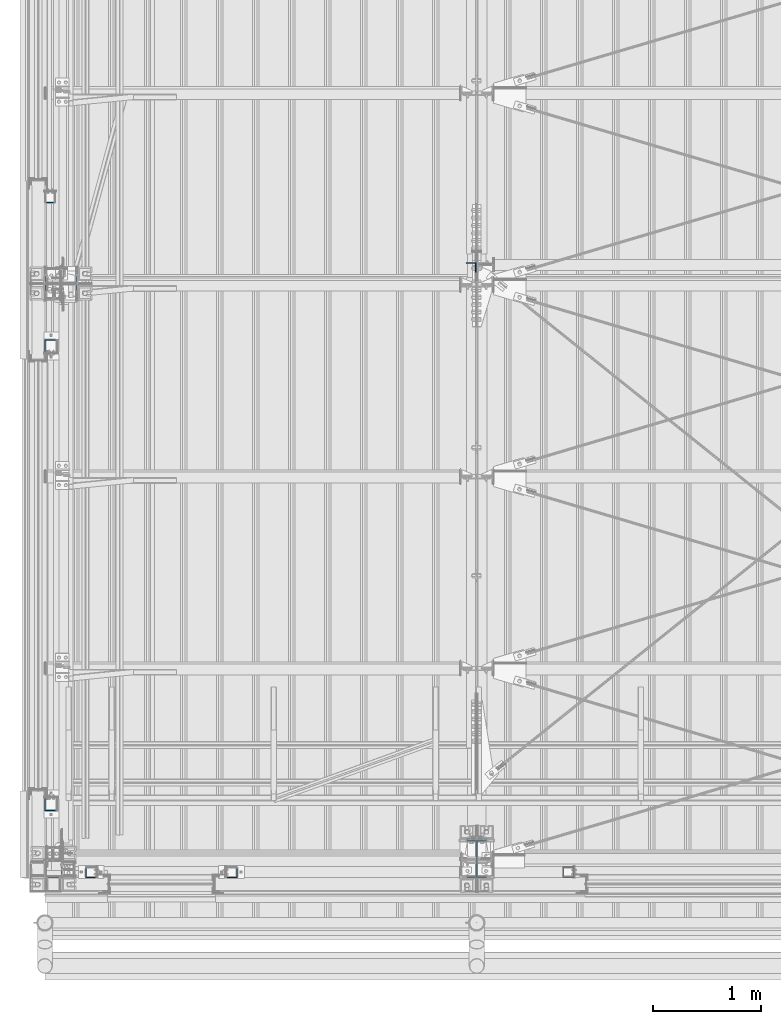
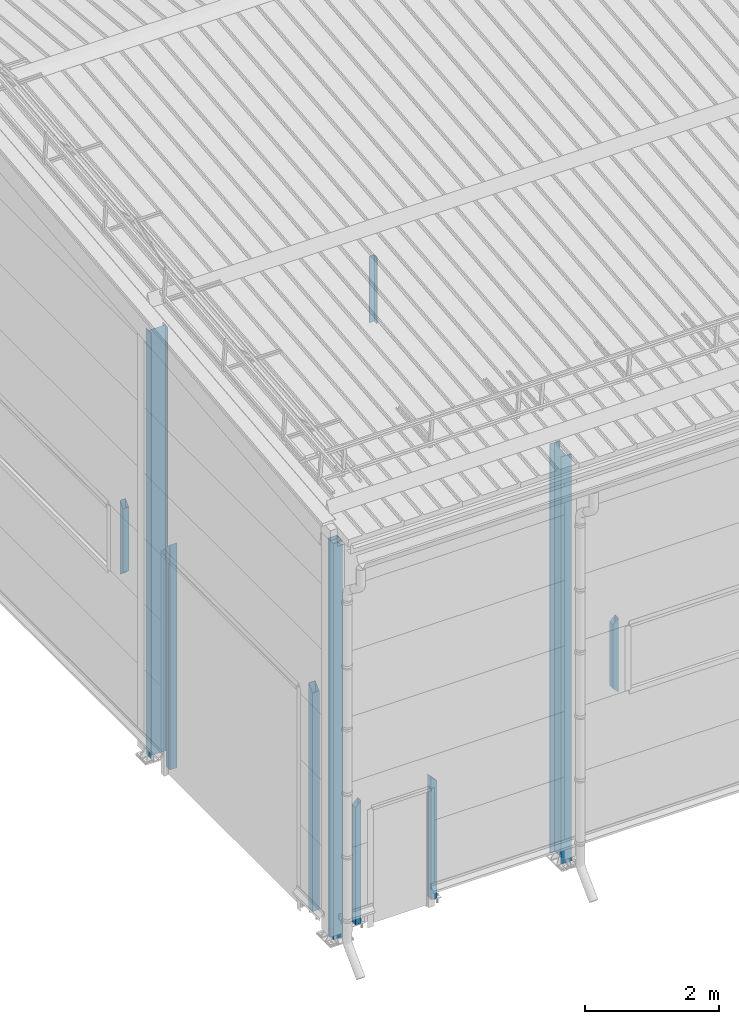
# One storey, part 225 of 709: 10 columns, 10 elements without a shape of their own.
"""IFC4 building model written with IfcOpenShell, lengths in millimetres."""

import ifcopenshell
import ifcopenshell.guid

model = None  # the IFC model being written
_history = None  # IfcOwnerHistory: only IFC2X3 demands one
_inside = {}  # id of a spatial element -> (the spatial element, [elements in it])
_under = {}  # id of a project, library or spatial element -> (it, [spatial elements below it])
_declared = {}  # id of a project -> (the project, [libraries it declares])
_typed = {}  # id of a type object -> (the type object, [elements of that type])
_made_of = {}  # id of a material, layer set ... -> (it, [elements and type objects made of it])


def new_model(schema):
    """Start an empty IFC model of exactly this schema.

    Asked for "IFC4X3", IfcOpenShell would pick the latest addendum, in which some entities
    have other attributes; the version numbers below select the first issue.
    IFC2X3 requires an IfcOwnerHistory on every rooted entity: one is made here for all.
    """
    global model, _history
    if schema == "IFC4X3":
        model = ifcopenshell.file(schema_version=(4, 3, 0, 0))
    else:
        model = ifcopenshell.file(schema=schema)
    _inside.clear()
    _under.clear()
    _declared.clear()
    _typed.clear()
    _made_of.clear()
    _history = None
    if model.schema == "IFC2X3":
        org = make("IfcOrganization", Name="unknown")
        user = make(
            "IfcPersonAndOrganization",
            ThePerson=make("IfcPerson", FamilyName="unknown"),
            TheOrganization=org,
        )
        app = make(
            "IfcApplication",
            ApplicationDeveloper=org,
            Version="unknown",
            ApplicationFullName="unknown",
            ApplicationIdentifier="unknown",
        )
        _history = make(
            "IfcOwnerHistory",
            OwningUser=user,
            OwningApplication=app,
            ChangeAction="ADDED",
            CreationDate=0,
        )
    return model


def make(cls, **values):
    """One entity of the class cls with the attributes given. An attribute that is None is left unset."""
    return model.create_entity(
        cls, **{name: value for name, value in values.items() if value is not None}
    )


def rooted(cls, **values):
    """An entity with a GlobalId (a new one), such as an element, a storey or a relation."""
    return make(cls, GlobalId=ifcopenshell.guid.new(), OwnerHistory=_history, **values)


def si_unit(unit_type, name, prefix=None):
    """IfcSIUnit, for example si_unit("LENGTHUNIT", "METRE", prefix="MILLI")."""
    return make("IfcSIUnit", UnitType=unit_type, Prefix=prefix, Name=name)


def assignment(units):
    """IfcUnitAssignment: the units of a project."""
    return None if units is None else make("IfcUnitAssignment", Units=units)


def point(xyz):
    """IfcCartesianPoint."""
    return None if xyz is None else make("IfcCartesianPoint", Coordinates=xyz)


def direction(xyz):
    """IfcDirection."""
    return None if xyz is None else make("IfcDirection", DirectionRatios=xyz)


def frame(location, z_axis=None, x_axis=None):
    """IfcAxis2Placement3D, a coordinate frame: its origin and axes. An axis left out is left unset."""
    return make(
        "IfcAxis2Placement3D",
        Location=point(location),
        Axis=direction(z_axis),
        RefDirection=direction(x_axis),
    )


def origin_with_axes():
    """The frame at (0, 0, 0) with the z axis (0, 0, 1) and the x axis (1, 0, 0) written out."""
    return frame((0.0, 0.0, 0.0), z_axis=(0.0, 0.0, 1.0), x_axis=(1.0, 0.0, 0.0))


def place(relative_to, where):
    """IfcLocalPlacement: puts the frame where relative to a parent placement (None: the world)."""
    return make(
        "IfcLocalPlacement", PlacementRelTo=relative_to, RelativePlacement=where
    )


def context(
    kind, dimensions, precision=None, world=None, true_north=None, identifier=None
):
    """IfcGeometricRepresentationContext, for example the 3D "Model" context."""
    return make(
        "IfcGeometricRepresentationContext",
        ContextIdentifier=identifier,
        ContextType=kind,
        CoordinateSpaceDimension=dimensions,
        Precision=precision,
        WorldCoordinateSystem=world,
        TrueNorth=true_north,
    )


def subcontext(parent, identifier, kind, view, scale=None):
    """IfcGeometricRepresentationSubContext, for example "Body" below "Model"."""
    return make(
        "IfcGeometricRepresentationSubContext",
        ContextIdentifier=identifier,
        ContextType=kind,
        ParentContext=parent,
        TargetScale=scale,
        TargetView=view,
    )


def project(units=None, contexts=None):
    """IfcProject with its units and contexts."""
    return rooted(
        "IfcProject",
        Name="project",
        RepresentationContexts=contexts,
        UnitsInContext=assignment(units),
    )


def spatial(cls, under=None, at=None, **own):
    """A site, building, storey or space (cls), placed at a placement, below another one or the project."""
    s = rooted(cls, ObjectPlacement=at, **own)
    if under is not None:
        _under.setdefault(under.id(), (under, []))[1].append(s)
    return s


def point_list(points):
    """IfcCartesianPointList2D or 3D."""
    cls = (
        "IfcCartesianPointList2D" if len(points[0]) == 2 else "IfcCartesianPointList3D"
    )
    return make(cls, CoordList=points)


def polygons(points, faces, closed=None, point_numbers=None):
    """IfcPolygonalFaceSet: a face is its outer loop, then its inner loops; points numbered from 1."""
    made = []
    for loops in faces:
        if len(loops) == 1:
            made.append(make("IfcIndexedPolygonalFace", CoordIndex=loops[0]))
        else:
            made.append(
                make(
                    "IfcIndexedPolygonalFaceWithVoids",
                    CoordIndex=loops[0],
                    InnerCoordIndices=loops[1:],
                )
            )
    return make(
        "IfcPolygonalFaceSet",
        Coordinates=point_list(points),
        Closed=closed,
        Faces=made,
        PnIndex=point_numbers,
    )


def shape(context_of_items, identifier, shape_type, items):
    """IfcShapeRepresentation: the items that make up one representation, for example the "Body"."""
    return make(
        "IfcShapeRepresentation",
        ContextOfItems=context_of_items,
        RepresentationIdentifier=identifier,
        RepresentationType=shape_type,
        Items=items,
    )


def material(Name=None, Category=None):
    """IfcMaterial."""
    return make("IfcMaterial", Name=Name, Category=Category)


def made_of(thing, what):
    """Note that an element or type object is made of a material, layer set ...; save() writes the relation."""
    if what is not None:
        _made_of.setdefault(what.id(), (what, []))[1].append(thing)
    return thing


def element(
    cls,
    number,
    at=None,
    inside=None,
    cuts=None,
    type_object=None,
    material=None,
    context=None,
    identifier="Body",
    shape_type=None,
    held_by="IfcProductDefinitionShape",
    body=None,
    shapes=None,
    **own,
):
    """One element of the class cls, such as IfcWall. Its Tag is "e" and its number.

    at: its placement. inside: the storey or other place that contains it. cuts: it is an
    opening in that element (IfcRelVoidsElement). A single representation is given by context,
    identifier, shape_type and body (its items); several are given by shapes. held_by: the class
    of the entity that holds the representations. save() writes the other relations.
    """
    e = rooted(cls, Tag="e%d" % number, ObjectPlacement=at, **own)
    if body is not None:
        shapes = [shape(context, identifier, shape_type, body)]
    if shapes is not None:
        e.Representation = make(held_by, Representations=shapes)
    if inside is not None:
        _inside.setdefault(inside.id(), (inside, []))[1].append(e)
    if cuts is not None:
        rooted(
            "IfcRelVoidsElement", RelatingBuildingElement=cuts, RelatedOpeningElement=e
        )
    if type_object is not None:
        _typed.setdefault(type_object.id(), (type_object, []))[1].append(e)
    return made_of(e, material)


def aggregate(whole, parts):
    """IfcRelAggregates: a whole, such as a stair, and the parts it consists of."""
    return rooted("IfcRelAggregates", RelatingObject=whole, RelatedObjects=parts)


def save(model, path):
    """Write the relations noted so far, then the file.

    IfcRelAggregates (storeys below a building ...), IfcRelContainedInSpatialStructure (elements
    in a storey), IfcRelDefinesByType, IfcRelAssociatesMaterial and IfcRelDeclares: one each for
    every whole, place, type object, material and project.
    """
    for whole, parts in _under.values():
        aggregate(whole, parts)
    for where, things in _inside.values():
        rooted(
            "IfcRelContainedInSpatialStructure",
            RelatedElements=things,
            RelatingStructure=where,
        )
    for kind, things in _typed.values():
        rooted("IfcRelDefinesByType", RelatedObjects=things, RelatingType=kind)
    for what, things in _made_of.values():
        rooted("IfcRelAssociatesMaterial", RelatedObjects=things, RelatingMaterial=what)
    for by, libraries in _declared.values():
        rooted("IfcRelDeclares", RelatingContext=by, RelatedDefinitions=libraries)
    model.write(path)


model = new_model("IFC4")

# Units and contexts
model_context = context("Model", 3, precision=0.2, world=origin_with_axes(), true_north=direction((0.0, 1.0)))
body_context = subcontext(model_context, "Body", "Model", "MODEL_VIEW")
ifc_project = project(units=[si_unit("LENGTHUNIT", "METRE", prefix="MILLI"), si_unit("AREAUNIT", "SQUARE_METRE"), si_unit("VOLUMEUNIT", "CUBIC_METRE"), si_unit("MASSUNIT", "GRAM", prefix="KILO"), si_unit("TIMEUNIT", "SECOND"), si_unit("PLANEANGLEUNIT", "RADIAN"), si_unit("SOLIDANGLEUNIT", "STERADIAN"), si_unit("THERMODYNAMICTEMPERATUREUNIT", "DEGREE_CELSIUS"), si_unit("LUMINOUSINTENSITYUNIT", "LUMEN")], contexts=[model_context])

# Site, building, storey
site_placement = place(None, origin_with_axes())
site = spatial("IfcSite", under=ifc_project, at=site_placement, CompositionType="ELEMENT")
building_placement = place(site_placement, origin_with_axes())
building = spatial("IfcBuilding", under=site, at=building_placement, Name="Undefined", CompositionType="ELEMENT")
storey_placement = place(building_placement, origin_with_axes())
storey = spatial("IfcBuildingStorey", under=building, at=storey_placement, Name="Undefined", CompositionType="ELEMENT", Elevation=0.0)

# Assembly, column
assembly_1_placement = place(storey_placement, frame((4000.0, 173.0, -200.0), z_axis=(-1.0, 0.0, 0.0), x_axis=(0.0, 0.0, 1.0)))
assembly_1 = element("IfcElementAssembly", 1, at=assembly_1_placement, inside=storey)
ifc_material_1 = material(Name="C355-5", Category="STEEL")
column_1_placement = place(assembly_1_placement, origin_with_axes())
column_1 = element("IfcColumn", 2, at=column_1_placement, material=ifc_material_1, ObjectType="413", context=body_context, shape_type="Tessellation", body=[
    polygons([(25.0, -173.0, -87.0), (25.0, -164.0, -87.0), (7421.82297, -164.0, -87.0), (7420.92297, -173.0, -87.0), (25.0, -164.0, -3.0), (7421.82297, -164.0, -3.0), (25.0, 164.0, -3.0), (7454.62297, 164.0, -3.0), (25.0, 164.0, -87.0), (7454.62297, 164.0, -87.0), (25.0, 173.0, -87.0), (7455.52297, 173.0, -87.0), (25.0, 173.0, 87.0), (7455.52297, 173.0, 87.0), (25.0, 164.0, 87.0), (7454.62297, 164.0, 87.0), (25.0, 164.0, 3.0), (7454.62297, 164.0, 3.0), (25.0, -164.0, 3.0), (7421.82297, -164.0, 3.0), (25.0, -164.0, 87.0), (7421.82297, -164.0, 87.0), (25.0, -173.0, 87.0), (7420.92297, -173.0, 87.0)], [[[1, 2, 3, 4]], [[2, 5, 6, 3]], [[5, 7, 8, 6]], [[7, 9, 10, 8]], [[9, 11, 12, 10]], [[11, 13, 14, 12]], [[13, 15, 16, 14]], [[15, 17, 18, 16]], [[17, 19, 20, 18]], [[19, 21, 22, 20]], [[21, 23, 24, 22]], [[23, 1, 4, 24]], [[6, 8, 10, 12, 14, 16, 18, 20, 22, 24, 4, 3]], [[23, 21, 19, 17, 15, 13, 11, 9, 7, 5, 2, 1]]], closed=True),
])
aggregate(assembly_1, [column_1])

assembly_2_placement = place(storey_placement, frame((149.0, 5500.0, -200.0), z_axis=(0.0, -1.0, 0.0), x_axis=(0.0, 0.0, 1.0)))
assembly_2 = element("IfcElementAssembly", 3, at=assembly_2_placement, inside=storey)
ifc_material_2 = material(Name="C255-4", Category="STEEL")
column_2_placement = place(assembly_2_placement, origin_with_axes())
column_2 = element("IfcColumn", 4, at=column_2_placement, material=ifc_material_2, ObjectType="414", context=body_context, shape_type="Tessellation", body=[
    polygons([(25.0, -149.0, -74.5), (25.0, -141.0, -74.5), (7765.31561, -141.0, -74.5), (7765.31561, -149.0, -74.5), (25.0, -141.0, -2.75), (7758.14061, -141.0, -2.75), (25.0, 141.0, -2.75), (7758.14061, 141.0, -2.75), (25.0, 141.0, -74.5), (7765.31561, 141.0, -74.5), (25.0, 149.0, -74.5), (7765.31561, 149.0, -74.5), (25.0, 149.0, 74.5), (7750.41561, 149.0, 74.5), (25.0, 141.0, 74.5), (7750.41561, 141.0, 74.5), (25.0, 141.0, 2.75), (7757.59061, 141.0, 2.75), (25.0, -141.0, 2.75), (7757.59061, -141.0, 2.75), (25.0, -141.0, 74.5), (7750.41561, -141.0, 74.5), (25.0, -149.0, 74.5), (7750.41561, -149.0, 74.5)], [[[1, 2, 3, 4]], [[2, 5, 6, 3]], [[5, 7, 8, 6]], [[7, 9, 10, 8]], [[9, 11, 12, 10]], [[11, 13, 14, 12]], [[13, 15, 16, 14]], [[15, 17, 18, 16]], [[17, 19, 20, 18]], [[19, 21, 22, 20]], [[21, 23, 24, 22]], [[23, 1, 4, 24]], [[6, 8, 10, 12, 14, 16, 18, 20, 22, 24, 4, 3]], [[23, 21, 19, 17, 15, 13, 11, 9, 7, 5, 2, 1]]], closed=True),
])
aggregate(assembly_2, [column_2])

assembly_3_placement = place(storey_placement, frame((80.0, 80.0, -200.0), z_axis=(0.0, -1.0, 0.0), x_axis=(0.0, 0.0, 1.0)))
assembly_3 = element("IfcElementAssembly", 5, at=assembly_3_placement, inside=storey)
column_3_placement = place(assembly_3_placement, origin_with_axes())
column_3 = element("IfcColumn", 6, at=column_3_placement, material=ifc_material_2, ObjectType="412", context=body_context, shape_type="Tessellation", body=[
    polygons([(25.0, -74.0, -74.0), (25.0, -74.0, 74.0), (7212.48556, -74.0, 74.0), (7227.28556, -74.0, -74.0), (25.0, 74.0, 74.0), (7212.48556, 74.0, 74.0), (25.0, 74.0, -74.0), (7227.28556, 74.0, -74.0), (25.0, -80.0, -80.0), (25.0, 80.0, -80.0), (7227.88556, 80.0, -80.0), (7227.88556, -80.0, -80.0), (25.0, 80.0, 80.0), (7211.88556, 80.0, 80.0), (25.0, -80.0, 80.0), (7211.88556, -80.0, 80.0)], [[[1, 2, 3, 4]], [[2, 5, 6, 3]], [[5, 7, 8, 6]], [[7, 1, 4, 8]], [[9, 10, 11, 12]], [[10, 13, 14, 11]], [[13, 15, 16, 14]], [[15, 9, 12, 16]], [[14, 16, 12, 11], [6, 8, 4, 3]], [[15, 13, 10, 9], [7, 5, 2, 1]]], closed=True),
])
aggregate(assembly_3, [column_3])

assembly_4_placement = place(storey_placement, frame((3949.0, 5648.7, 6024.30002), z_axis=(0.0, -1.0, 0.0), x_axis=(0.0, 0.0, 1.0)))
assembly_4 = element("IfcElementAssembly", 7, at=assembly_4_placement, inside=storey)
ifc_material_3 = material(Name="C345-5", Category="STEEL")
column_4_placement = place(assembly_4_placement, origin_with_axes())
column_4 = element("IfcColumn", 8, at=column_4_placement, material=ifc_material_3, ObjectType="436", context=body_context, shape_type="Tessellation", body=[
    polygons([(185.7, -45.0, -45.0), (185.7, 45.0, -45.0), (1399.0509, 45.0, -45.0), (1399.0509, -45.0, -45.0), (185.7, 45.0, -39.0), (1399.0509, 45.0, -39.0), (185.7, -39.0, -39.0), (1399.0509, -39.0, -39.0), (185.7, -39.0, 45.0), (1399.0509, -39.0, 45.0), (185.7, -45.0, 45.0), (1399.0509, -45.0, 45.0)], [[[1, 2, 3, 4]], [[2, 5, 6, 3]], [[5, 7, 8, 6]], [[7, 9, 10, 8]], [[9, 11, 12, 10]], [[11, 1, 4, 12]], [[6, 8, 10, 12, 4, 3]], [[11, 9, 7, 5, 2, 1]]], closed=True),
])
aggregate(assembly_4, [column_4])

assembly_5_placement = place(storey_placement, frame((50.0, 6300.0, 2600.0), z_axis=(0.0, -1.0, 0.0), x_axis=(0.0, 0.0, 1.0)))
assembly_5 = element("IfcElementAssembly", 9, at=assembly_5_placement, inside=storey)
ifc_material_4 = material(Name="C355", Category="STEEL")
column_5_placement = place(assembly_5_placement, origin_with_axes())
column_5 = element("IfcColumn", 10, at=column_5_placement, material=ifc_material_4, ObjectType="493", context=body_context, shape_type="Tessellation", body=[
    polygons([(10.0, -50.0, -50.0), (10.0, 50.0, -50.0), (1360.0, 50.0, -50.0), (1360.0, -50.0, -50.0), (110.0, -50.0, 50.0), (1260.0, -50.0, 50.0), (110.0, 50.0, 50.0), (1260.0, 50.0, 50.0), (107.0, 47.0, 47.0), (13.0, 47.0, -47.0), (1357.0, 47.0, -47.0), (1263.0, 47.0, 47.0), (107.0, -47.0, 47.0), (1263.0, -47.0, 47.0), (13.0, -47.0, -47.0), (1357.0, -47.0, -47.0)], [[[1, 2, 3, 4]], [[5, 1, 4, 6]], [[7, 5, 6, 8]], [[2, 7, 8, 3]], [[1, 5, 7, 2], [15, 10, 9, 13]], [[9, 10, 11, 12]], [[13, 9, 12, 14]], [[15, 13, 14, 16]], [[10, 15, 16, 11]], [[6, 4, 3, 8], [14, 12, 11, 16]]], closed=True),
])
aggregate(assembly_5, [column_5])

assembly_6_placement = place(storey_placement, frame((60.0, 4920.0, -50.0), z_axis=(0.0, -1.0, 0.0), x_axis=(0.0, 0.0, 1.0)))
assembly_6 = element("IfcElementAssembly", 11, at=assembly_6_placement, inside=storey)
ifc_material_5 = material(Name="C255", Category="STEEL")
column_6_placement = place(assembly_6_placement, origin_with_axes())
column_6 = element("IfcColumn", 12, at=column_6_placement, material=ifc_material_5, ObjectType="530", context=body_context, shape_type="Tessellation", body=[
    polygons([(12.0, -60.0, 60.0), (12.0, -60.0, -60.0), (3980.0, -60.0, -60.0), (4100.0, -60.0, 60.0), (12.0, 60.0, 60.0), (4100.0, 60.0, 60.0), (12.0, 60.0, -60.0), (3980.0, 60.0, -60.0), (12.0, -56.0, 56.0), (12.0, 56.0, 56.0), (4096.0, 56.0, 56.0), (4096.0, -56.0, 56.0), (12.0, -56.0, -56.0), (3984.0, -56.0, -56.0), (12.0, 56.0, -56.0), (3984.0, 56.0, -56.0)], [[[1, 2, 3, 4]], [[5, 1, 4, 6]], [[7, 5, 6, 8]], [[2, 7, 8, 3]], [[1, 5, 7, 2], [15, 10, 9, 13]], [[9, 10, 11, 12]], [[13, 9, 12, 14]], [[15, 13, 14, 16]], [[10, 15, 16, 11]], [[3, 8, 6, 4], [14, 12, 11, 16]]], closed=True),
])
aggregate(assembly_6, [column_6])

assembly_7_placement = place(storey_placement, frame((60.0, 680.0, -50.0), z_axis=(0.0, -1.0, 0.0), x_axis=(0.0, 0.0, 1.0)))
assembly_7 = element("IfcElementAssembly", 13, at=assembly_7_placement, inside=storey)
column_7_placement = place(assembly_7_placement, origin_with_axes())
column_7 = element("IfcColumn", 14, at=column_7_placement, material=ifc_material_5, ObjectType="530", context=body_context, shape_type="Tessellation", body=[
    polygons([(12.0, -60.0, 60.0), (12.0, -60.0, -60.0), (4100.0, -60.0, -60.0), (3980.0, -60.0, 60.0), (12.0, 60.0, 60.0), (3980.0, 60.0, 60.0), (12.0, 60.0, -60.0), (4100.0, 60.0, -60.0), (12.0, 56.0, 56.0), (12.0, 56.0, -56.0), (4096.0, 56.0, -56.0), (3984.0, 56.0, 56.0), (12.0, -56.0, 56.0), (3984.0, -56.0, 56.0), (12.0, -56.0, -56.0), (4096.0, -56.0, -56.0)], [[[1, 2, 3, 4]], [[5, 1, 4, 6]], [[7, 5, 6, 8]], [[2, 7, 8, 3]], [[1, 5, 7, 2], [10, 9, 13, 15]], [[9, 10, 11, 12]], [[13, 9, 12, 14]], [[15, 13, 14, 16]], [[10, 15, 16, 11]], [[4, 3, 8, 6], [14, 12, 11, 16]]], closed=True),
])
aggregate(assembly_7, [column_7])

assembly_8_placement = place(storey_placement, frame((430.0, 50.0, -50.0), z_axis=(1.0, 0.0, 0.0), x_axis=(0.0, 0.0, 1.0)))
assembly_8 = element("IfcElementAssembly", 15, at=assembly_8_placement, inside=storey)
column_8_placement = place(assembly_8_placement, origin_with_axes())
column_8 = element("IfcColumn", 16, at=column_8_placement, material=ifc_material_4, ObjectType="541", context=body_context, shape_type="Tessellation", body=[
    polygons([(12.0, -50.0, 50.0), (12.0, -50.0, -50.0), (2140.0, -50.0, -50.0), (2240.0, -50.0, 50.0), (12.0, 50.0, 50.0), (2240.0, 50.0, 50.0), (12.0, 50.0, -50.0), (2140.0, 50.0, -50.0), (12.0, -47.0, 47.0), (12.0, 47.0, 47.0), (2237.0, 47.0, 47.0), (2237.0, -47.0, 47.0), (12.0, -47.0, -47.0), (2143.0, -47.0, -47.0), (12.0, 47.0, -47.0), (2143.0, 47.0, -47.0)], [[[1, 2, 3, 4]], [[5, 1, 4, 6]], [[7, 5, 6, 8]], [[2, 7, 8, 3]], [[1, 5, 7, 2], [15, 10, 9, 13]], [[9, 10, 11, 12]], [[13, 9, 12, 14]], [[15, 13, 14, 16]], [[10, 15, 16, 11]], [[3, 8, 6, 4], [14, 12, 11, 16]]], closed=True),
])
aggregate(assembly_8, [column_8])

assembly_9_placement = place(storey_placement, frame((1730.0, 50.0, -50.0), z_axis=(1.0, 0.0, 0.0), x_axis=(0.0, 0.0, 1.0)))
assembly_9 = element("IfcElementAssembly", 17, at=assembly_9_placement, inside=storey)
column_9_placement = place(assembly_9_placement, origin_with_axes())
column_9 = element("IfcColumn", 18, at=column_9_placement, material=ifc_material_4, ObjectType="541", context=body_context, shape_type="Tessellation", body=[
    polygons([(12.0, -50.0, 50.0), (12.0, -50.0, -50.0), (2240.0, -50.0, -50.0), (2140.0, -50.0, 50.0), (12.0, 50.0, 50.0), (2140.0, 50.0, 50.0), (12.0, 50.0, -50.0), (2240.0, 50.0, -50.0), (12.0, 47.0, 47.0), (12.0, 47.0, -47.0), (2237.0, 47.0, -47.0), (2143.0, 47.0, 47.0), (12.0, -47.0, 47.0), (2143.0, -47.0, 47.0), (12.0, -47.0, -47.0), (2237.0, -47.0, -47.0)], [[[1, 2, 3, 4]], [[5, 1, 4, 6]], [[7, 5, 6, 8]], [[2, 7, 8, 3]], [[1, 5, 7, 2], [10, 9, 13, 15]], [[9, 10, 11, 12]], [[13, 9, 12, 14]], [[15, 13, 14, 16]], [[10, 15, 16, 11]], [[4, 3, 8, 6], [14, 12, 11, 16]]], closed=True),
])
aggregate(assembly_9, [column_9])

assembly_10_placement = place(storey_placement, frame((4850.0, 50.0, 2600.0), z_axis=(1.0, 0.0, 0.0), x_axis=(0.0, 0.0, 1.0)))
assembly_10 = element("IfcElementAssembly", 19, at=assembly_10_placement, inside=storey)
column_10_placement = place(assembly_10_placement, origin_with_axes())
column_10 = element("IfcColumn", 20, at=column_10_placement, material=ifc_material_4, ObjectType="493", context=body_context, shape_type="Tessellation", body=[
    polygons([(10.0, -50.0, 50.0), (110.0, -50.0, -50.0), (1260.0, -50.0, -50.0), (1360.0, -50.0, 50.0), (10.0, 50.0, 50.0), (1360.0, 50.0, 50.0), (110.0, 50.0, -50.0), (1260.0, 50.0, -50.0), (13.0, -47.0, 47.0), (13.0, 47.0, 47.0), (1357.0, 47.0, 47.0), (1357.0, -47.0, 47.0), (107.0, -47.0, -47.0), (1263.0, -47.0, -47.0), (107.0, 47.0, -47.0), (1263.0, 47.0, -47.0)], [[[1, 2, 3, 4]], [[5, 1, 4, 6]], [[7, 5, 6, 8]], [[2, 7, 8, 3]], [[1, 5, 7, 2], [9, 13, 15, 10]], [[9, 10, 11, 12]], [[13, 9, 12, 14]], [[15, 13, 14, 16]], [[10, 15, 16, 11]], [[3, 8, 6, 4], [14, 12, 11, 16]]], closed=True),
])
aggregate(assembly_10, [column_10])

save(model, "model.ifc")
